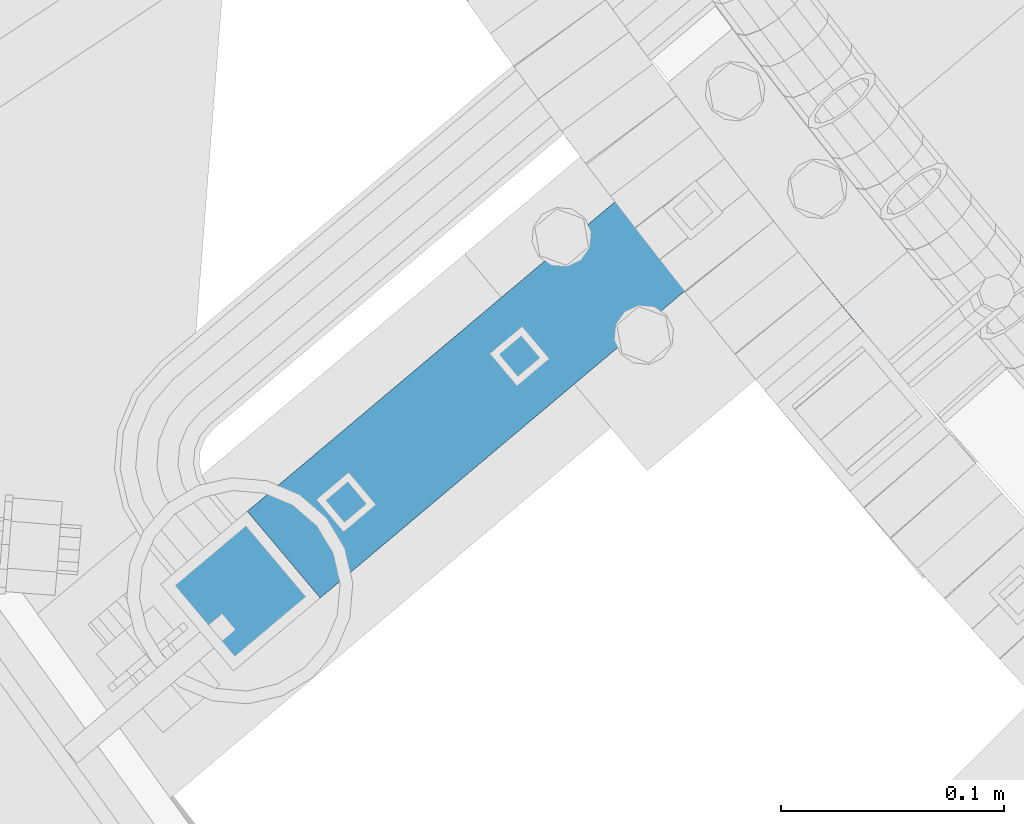
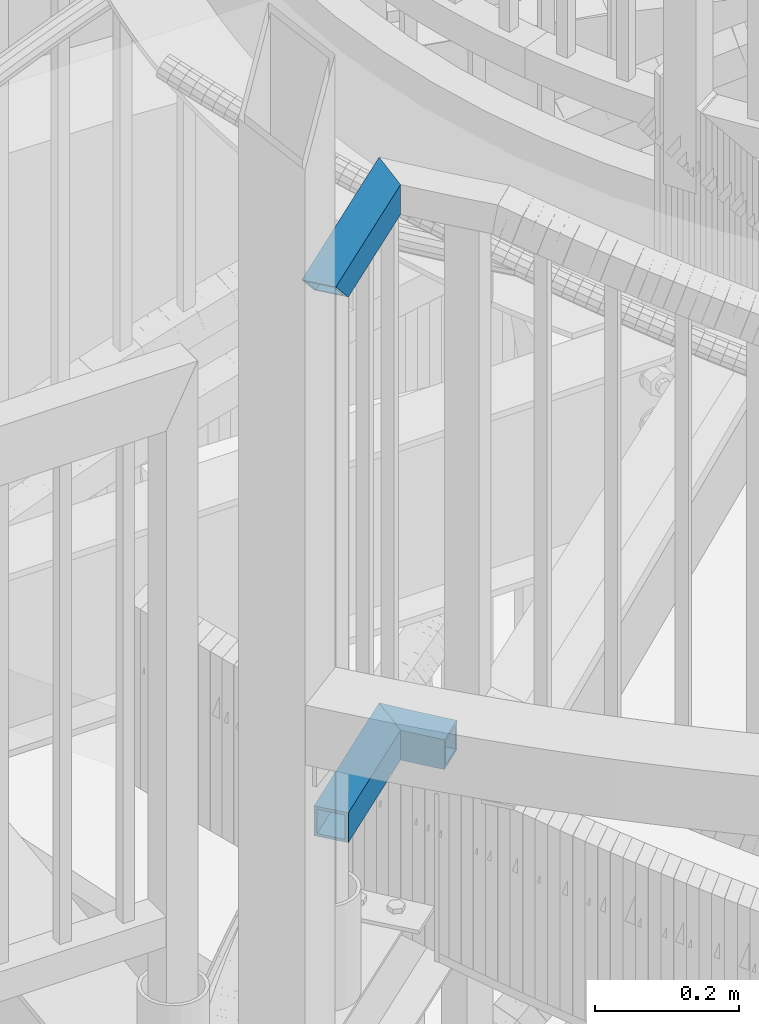
# One storey, part 463 of 975: 3 beams.
"""IFC2X3 building model written with IfcOpenShell, lengths in millimetres."""

from ifc_helpers import new_model, si_unit, frame, origin_with_axes, place, context, subcontext, project, spatial, faceted_brep, material, type_object, element, save


model = new_model("IFC2X3")

# Units and contexts
model_context = context("Model", 3, precision=1e-05, world=origin_with_axes())
body_context = subcontext(model_context, "Body", "Model", "MODEL_VIEW")
ifc_project = project(units=[si_unit("LENGTHUNIT", "METRE", prefix="MILLI"), si_unit("AREAUNIT", "SQUARE_METRE"), si_unit("VOLUMEUNIT", "CUBIC_METRE"), si_unit("MASSUNIT", "GRAM", prefix="KILO"), si_unit("TIMEUNIT", "SECOND"), si_unit("PLANEANGLEUNIT", "RADIAN"), si_unit("SOLIDANGLEUNIT", "STERADIAN"), si_unit("THERMODYNAMICTEMPERATUREUNIT", "DEGREE_CELSIUS"), si_unit("LUMINOUSINTENSITYUNIT", "LUMEN")], contexts=[model_context])

# Site, building, storey
site_placement = place(None, origin_with_axes())
site = spatial("IfcSite", under=ifc_project, at=site_placement, CompositionType="ELEMENT")
building_placement = place(site_placement, origin_with_axes())
building = spatial("IfcBuilding", under=site, at=building_placement, Name="Undefined", CompositionType="ELEMENT")
storey_placement = place(building_placement, origin_with_axes())
storey = spatial("IfcBuildingStorey", under=building, at=storey_placement, Name="Undefined", CompositionType="ELEMENT", Elevation=0.0)

# Beams
ifc_material = material()
beam_type = type_object("IfcBeamType", Name="HSS2X2X.188_TUBES", PredefinedType="NOTDEFINED")
beam_1_placement = place(storey_placement, frame((32546.1374942554, 1546.41999163262, 4203.6999526213), z_axis=(0.0, 0.0, 1.0), x_axis=(-0.631512226020782, 0.775365919025512, 0.0)))
element("IfcBeam", 1, at=beam_1_placement, inside=storey, type_object=beam_type, material=ifc_material, Name="HANDRAIL", ObjectType="HSS2X2X.188_TUBES", context=body_context, shape_type="Brep", body=[
    faceted_brep([(86.7867908267472, 25.8434800640825, -25.3999999999996), (84.8026851222021, 25.8625150428452, -25.3999999999996), (82.8185668398437, 25.8801904176144, -25.3999999999996), (82.8185668398437, 25.8801904176144, 25.3999999999996), (84.8026851222021, 25.8625150428452, 25.3999999999996), (86.7867908267472, 25.8434800640825, 25.3999999999996), (88.7708830218398, 25.8230854902686, 25.3999999999996), (88.7708830218398, 25.8230854902686, -25.3999999999996), (80.8344369113511, 25.8965061800955, -25.3999999999996), (78.8502962683924, 25.9114623226233, -25.3999999999996), (76.8661458426395, 25.9250588381765, -25.3999999999996), (76.8661458426395, 25.9250588381765, 25.3999999999996), (78.8502962683924, 25.9114623226233, 25.3999999999996), (80.8344369113511, 25.8965061800955, 25.3999999999996), (74.8819865657788, 25.9372957203668, -25.3999999999996), (72.8978193694929, 25.9481729634535, -25.3999999999996), (70.9136451854647, 25.9576905623289, -25.3999999999996), (70.9136451854647, 25.9576905623289, 25.3999999999996), (72.8978193694929, 25.9481729634535, 25.3999999999996), (74.8819865657788, 25.9372957203668, 25.3999999999996), (68.9294649453914, 25.9658485125146, -25.3999999999996), (66.9452795809702, 25.9726468101981, -25.3999999999996), (64.9610900238877, 25.9780854521705, -25.3999999999996), (64.9610900238877, 25.9780854521705, 25.3999999999996), (66.9452795809702, 25.9726468101981, 25.3999999999996), (68.9294649453914, 25.9658485125146, 25.3999999999996), (62.9768972058555, 25.982164435889, -25.3999999999996), (60.9927020585674, 25.9848837594291, -25.3999999999996), (59.0085055137242, 25.9862434215174, -25.3999999999996), (59.0085055137242, 25.9862434215174, 25.3999999999996), (60.9927020585674, 25.9848837594291, 25.3999999999996), (62.9768972058555, 25.982164435889, 25.3999999999996), (57.0243085030306, 25.9862434215174, -25.3999999999996), (55.0401119581875, 25.9848837594291, -25.3999999999996), (53.055916810903, 25.9821644358926, -25.3999999999996), (53.055916810903, 25.9821644358926, 25.3999999999996), (55.0401119581875, 25.9848837594291, 25.3999999999996), (57.0243085030306, 25.9862434215174, 25.3999999999996), (51.0717239928672, 25.9780854521778, -25.3999999999996), (49.0875344357883, 25.9726468102053, -25.3999999999996), (47.1033490713671, 25.9658485125256, -25.3999999999996), (47.1033490713671, 25.9658485125256, 25.3999999999996), (49.0875344357883, 25.9726468102053, 25.3999999999996), (51.0717239928672, 25.9780854521778, 25.3999999999996), (45.1191688312938, 25.9576905623398, -25.3999999999996), (43.1349946472656, 25.9481729634645, -25.3999999999996), (41.1508274509797, 25.9372957203777, -25.3999999999996), (41.1508274509797, 25.9372957203777, 25.3999999999996), (43.1349946472656, 25.9481729634645, 25.3999999999996), (45.1191688312938, 25.9576905623398, 25.3999999999996), (39.1666681741153, 25.9250588381874, -25.3999999999996), (37.1825177483624, 25.9114623226378, -25.3999999999996), (35.1983771054038, 25.8965061801136, -25.3999999999996), (35.1983771054038, 25.8965061801136, 25.3999999999996), (37.1825177483624, 25.9114623226378, 25.3999999999996), (39.1666681741153, 25.9250588381874, 25.3999999999996), (33.2142471769112, 25.8801904176362, -25.3999999999996), (31.2301288945564, 25.8625150428634, -25.3999999999996), (29.2460231900077, 25.8434800641007, -25.3999999999996), (29.2460231900077, 25.8434800641007, 25.3999999999996), (31.2301288945564, 25.8625150428634, 25.3999999999996), (33.2142471769112, 25.8801904176362, 25.3999999999996), (25.2778532409502, 25.8013313310003, 25.3999999999996), (27.2619309949187, 25.8230854902904, 25.3999999999996), (27.2619309949187, 25.8230854902904, -25.3999999999996), (25.2778532409502, 25.8013313310003, -25.3999999999996), (24.8836449103037, 25.7967389216101, -25.3999999999996), (24.8836449103037, 25.7967389216101, 25.3999999999996), (135.136666641316, -21.0948650812861, -20.6374999999998), (135.136666641316, -21.0948650812861, 20.6374999999998), (137.0885831946, -21.1483801701179, 20.6374999999998), (137.0885831946, -21.1483801701179, -20.6374999999998), (133.184713875333, -21.0426875470694, -20.6374999999998), (131.232725813206, -20.9918475919694, -20.6374999999998), (129.280703371518, -20.9423452398587, -20.6374999999998), (129.280703371518, -20.9423452398587, 20.6374999999998), (131.232725813206, -20.9918475919694, 20.6374999999998), (133.184713875333, -21.0426875470694, 20.6374999999998), (127.328647466864, -20.8941805139766, -20.6374999999998), (125.376559015855, -20.8473534369477, -20.6374999999998), (123.424438935112, -20.8018640307528, -20.6374999999998), (123.424438935112, -20.8018640307528, 20.6374999999998), (125.376559015855, -20.8473534369477, 20.6374999999998), (127.328647466864, -20.8941805139766, 20.6374999999998), (121.472288141274, -20.7577123167612, -20.6374999999998), (119.520107551009, -20.7148983156949, -20.6374999999998), (117.567898080972, -20.6734220476574, -20.6374999999998), (117.567898080972, -20.6734220476574, 20.6374999999998), (119.520107551009, -20.7148983156949, 20.6374999999998), (121.472288141274, -20.7577123167612, 20.6374999999998), (115.615660647847, -20.6332835321373, -20.6374999999998), (113.66339616834, -20.5944827879648, -20.6374999999998), (111.711105559141, -20.5570198333735, -20.6374999999998), (111.711105559141, -20.5570198333735, 20.6374999999998), (113.66339616834, -20.5944827879648, 20.6374999999998), (115.615660647847, -20.6332835321373, 20.6374999999998), (109.758789736985, -20.5208946859457, -20.6374999999998), (107.806449618602, -20.4861073626525, -20.6374999999998), (105.854086120737, -20.4526578798213, -20.6374999999998), (105.854086120737, -20.4526578798213, 20.6374999999998), (107.806449618602, -20.4861073626525, 20.6374999999998), (109.758789736985, -20.5208946859457, 20.6374999999998), (103.901700160135, -20.4205462531572, -20.6374999999998), (101.949292653568, -20.3897724977505, -20.6374999999998), (99.996864517816, -20.3603366280331, -20.6374999999998), (99.996864517816, -20.3603366280331, 20.6374999999998), (101.949292653568, -20.3897724977505, 20.6374999999998), (103.901700160135, -20.4205462531572, 20.6374999999998), (98.0444166696543, -20.3322386578438, -20.6374999999998), (96.0919500258824, -20.3054786003704, -20.6374999999998), (94.1394655033037, -20.2800564681747, -20.6374999999998), (94.1394655033037, -20.2800564681747, 20.6374999999998), (96.0919500258824, -20.3054786003704, 20.6374999999998), (98.0444166696543, -20.3322386578438, 20.6374999999998), (92.1869640187324, -20.2559722731967, -20.6374999999998), (90.2344464889793, -20.2332260267467, -20.6374999999998), (88.2819138308805, -20.2118177395059, -20.6374999999998), (88.2819138308805, -20.2118177395059, 20.6374999999998), (90.2344464889793, -20.2332260267467, 20.6374999999998), (92.1869640187324, -20.2559722731967, 20.6374999999998), (86.3293669612649, -20.1917474215261, -20.6374999999998), (84.3768067969722, -20.1730150822295, -20.6374999999998), (82.4242342548496, -20.1556207304129, -20.6374999999998), (82.4242342548496, -20.1556207304129, 20.6374999999998), (84.3768067969722, -20.1730150822295, 20.6374999999998), (86.3293669612649, -20.1917474215261, 20.6374999999998), (80.4716502517585, -20.1395643742435, -20.6374999999998), (78.5190557045462, -20.1248460212664, -20.6374999999998), (76.5664515300778, -20.1114656783866, -20.6374999999998), (76.5664515300778, -20.1114656783866, 20.6374999999998), (78.5190557045462, -20.1248460212664, 20.6374999999998), (80.4716502517585, -20.1395643742435, 20.6374999999998), (74.6138386452294, -20.0994233518832, -20.6374999999998), (72.6612179668664, -20.0887190474205, -20.6374999999998), (70.7085904118612, -20.0793527700225, -20.6374999999998), (70.7085904118612, -20.0793527700225, 20.6374999999998), (72.6612179668664, -20.0887190474205, 20.6374999999998), (74.6138386452294, -20.0994233518832, 20.6374999999998), (68.7559568970937, -20.0713245240804, -20.6374999999998), (66.8033183394509, -20.064634313374, -20.6374999999998), (64.8506756558163, -20.0592821410355, -20.6374999999998), (64.8506756558163, -20.0592821410355, 20.6374999999998), (66.8033183394509, -20.064634313374, 20.6374999999998), (68.7559568970937, -20.0713245240804, 20.6374999999998), (62.8980297630696, -20.0552680095825, -20.6374999999998), (60.9453815781017, -20.0525919208994, -20.6374999999998), (58.9927320177994, -20.051253876245, -20.6374999999998), (58.9927320177994, -20.051253876245, 20.6374999999998), (60.9453815781017, -20.0525919208994, 20.6374999999998), (62.8980297630696, -20.0552680095825, 20.6374999999998), (57.0400819990464, -20.051253876245, -20.6374999999998), (55.0874324387478, -20.0525919208958, -20.6374999999998), (53.1347842537798, -20.0552680095789, -20.6374999999998), (53.1347842537798, -20.0552680095789, 20.6374999999998), (55.0874324387478, -20.0525919208958, 20.6374999999998), (57.0400819990464, -20.051253876245, 20.6374999999998), (51.1821383610295, -20.0592821410282, -20.6374999999998), (49.2294956773949, -20.0646343133631, -20.6374999999998), (47.2768571197521, -20.0713245240731, -20.6374999999998), (47.2768571197521, -20.0713245240731, 20.6374999999998), (49.2294956773949, -20.0646343133631, 20.6374999999998), (51.1821383610295, -20.0592821410282, 20.6374999999998), (45.3242236049882, -20.079352770008, -20.6374999999998), (43.3715960499831, -20.0887190474095, -20.6374999999998), (41.4189753716164, -20.0994233518722, -20.6374999999998), (41.4189753716164, -20.0994233518722, 20.6374999999998), (43.3715960499831, -20.0887190474095, 20.6374999999998), (45.3242236049882, -20.079352770008, 20.6374999999998), (39.466362486768, -20.1114656783684, -20.6374999999998), (37.5137583123033, -20.1248460212519, -20.6374999999998), (35.5611637650909, -20.1395643742289, -20.6374999999998), (35.5611637650909, -20.1395643742289, 20.6374999999998), (37.5137583123033, -20.1248460212519, 20.6374999999998), (39.466362486768, -20.1114656783684, 20.6374999999998), (33.6085797619962, -20.1556207303947, -20.6374999999998), (31.6560072198772, -20.1730150822077, -20.6374999999998), (29.7034470555845, -20.1917474215043, -20.6374999999998), (29.7034470555845, -20.1917474215043, 20.6374999999998), (31.6560072198772, -20.1730150822077, 20.6374999999998), (33.6085797619962, -20.1556207303947, 20.6374999999998), (25.331699546492, 21.0391357422704, -20.6374999999998), (27.3125140146803, 21.0608541216898, -20.6374999999998), (29.2933429002369, 21.0812151518003, -20.6374999999998), (29.2933429002369, 21.0812151518003, 20.6374999999998), (27.3125140146803, 21.0608541216898, 20.6374999999998), (25.331699546492, 21.0391357422704, 20.6374999999998), (24.9799146229452, 21.0350375529088, 20.6374999999998), (24.9799146229452, 21.0350375529088, -20.6374999999998), (33.2550402029519, 21.1178651264563, 20.6374999999998), (31.274185273036, 21.1002188230304, 20.6374999999998), (31.274185273036, 21.1002188230304, -20.6374999999998), (33.2550402029519, 21.1178651264563, -20.6374999999998), (35.2359067598554, 21.1341540538015, -20.6374999999998), (35.2359067598554, 21.1341540538015, 20.6374999999998), (39.1976710340423, 21.1626597502691, 20.6374999999998), (37.216784013599, 21.149085597408, 20.6374999999998), (37.216784013599, 21.149085597408, -20.6374999999998), (39.1976710340423, 21.1626597502691, -20.6374999999998), (41.1785668910452, 21.1748765060074, -20.6374999999998), (41.1785668910452, 21.1748765060074, 20.6374999999998), (45.1403813940888, 21.1952378038186, 20.6374999999998), (43.159470654442, 21.1857358588895, 20.6374999999998), (43.159470654442, 21.1857358588895, -20.6374999999998), (45.1403813940888, 21.1952378038186, -20.6374999999998), (47.1212981798199, 21.2033823363272, -20.6374999999998), (47.1212981798199, 21.2033823363272, 20.6374999999998), (51.0831461688831, 21.2155991494328, 20.6374999999998), (49.1022200814732, 21.2101694525954, 20.6374999999998), (49.1022200814732, 21.2101694525954, -20.6374999999998), (51.0831461688831, 21.2155991494328, -20.6374999999998), (53.0640755118875, 21.2196714242891, -20.6374999999998), (53.0640755118875, 21.2196714242891, 20.6374999999998), (57.0259402440024, 21.223743701059, 20.6374999999998), (55.0450071803134, 21.222386275258, 20.6374999999998), (55.0450071803134, 21.222386275258, -20.6374999999998), (57.0259402440024, 21.223743701059, -20.6374999999998), (59.006873772767, 21.223743701059, -20.6374999999998), (59.006873772767, 21.223743701059, 20.6374999999998), (62.9687385048783, 21.2196714242855, 20.6374999999998), (60.9878068364487, 21.2223862752544, 20.6374999999998), (60.9878068364487, 21.2223862752544, -20.6374999999998), (62.9687385048783, 21.2196714242855, -20.6374999999998), (64.9496678478827, 21.2155991494292, -20.6374999999998), (64.9496678478827, 21.2155991494292, 20.6374999999998), (68.9115158369459, 21.2033823363163, 20.6374999999998), (66.9305939352926, 21.2101694525845, 20.6374999999998), (66.9305939352926, 21.2101694525845, -20.6374999999998), (68.9115158369459, 21.2033823363163, -20.6374999999998), (70.892432622677, 21.1952378038077, -20.6374999999998), (70.892432622677, 21.1952378038077, 20.6374999999998), (74.8542471257242, 21.1748765059965, 20.6374999999998), (72.8733433623238, 21.1857358588823, 20.6374999999998), (72.8733433623238, 21.1857358588823, -20.6374999999998), (74.8542471257242, 21.1748765059965, -20.6374999999998), (76.8351429827235, 21.1626597502509, -20.6374999999998), (76.8351429827235, 21.1626597502509, 20.6374999999998), (80.7969072569103, 21.1341540537869, 20.6374999999998), (78.8160300031668, 21.1490855973898, 20.6374999999998), (78.8160300031668, 21.1490855973898, -20.6374999999998), (80.7969072569103, 21.1341540537869, -20.6374999999998), (82.7777738138138, 21.1178651264418, -20.6374999999998), (82.7777738138138, 21.1178651264418, 20.6374999999998), (86.7394711165252, 21.0812151517785, 20.6374999999998), (84.7586287437298, 21.1002188230086, 20.6374999999998), (84.7586287437298, 21.1002188230086, -20.6374999999998), (86.7394711165252, 21.0812151517785, -20.6374999999998), (88.7203000020818, 21.0608541216716, -20.6374999999998), (88.7203000020818, 21.0608541216716, 20.6374999999998), (92.6819135909827, 21.0160600237032, 20.6374999999998), (90.7011144702738, 21.0391357422486, 20.6374999999998), (90.7011144702738, 21.0391357422486, -20.6374999999998), (92.6819135909827, 21.0160600237032, -20.6374999999998), (94.6626964341085, 20.9916269768764, -20.6374999999998), (94.6626964341085, 20.9916269768764, 20.6374999999998), (95.1996714824563, 20.984635346209, -20.6374999999998), (95.1996714824563, 20.984635346209, 20.6374999999998), (27.7509001859689, -20.2118177394841, 20.6374999999998), (25.7983675278665, -20.2332260267249, 20.6374999999998), (25.7983675278665, -20.2332260267249, -20.6374999999998), (27.7509001859689, -20.2118177394841, -20.6374999999998), (25.8522138334083, -24.9954216154547, -25.3999999999996), (25.8522138334083, -24.9954216154547, 25.3999999999996), (27.8014832057306, -24.9740491080775, -25.3999999999996), (29.7507667658174, -24.954012333812, -25.3999999999996), (29.7507667658174, -24.954012333812, 25.3999999999996), (27.8014832057306, -24.9740491080775, 25.3999999999996), (33.649372788037, -24.917946021571, 25.3999999999996), (31.7000635983568, -24.9353113020443, 25.3999999999996), (31.7000635983568, -24.9353113020443, -25.3999999999996), (33.649372788037, -24.917946021571, -25.3999999999996), (35.5986934195389, -24.9019165005375, -25.3999999999996), (35.5986934195389, -24.9019165005375, 25.3999999999996), (39.497365346695, -24.8738647662904, 25.3999999999996), (37.5480245775361, -24.8872227464781, 25.3999999999996), (37.5480245775361, -24.8872227464781, -25.3999999999996), (39.497365346695, -24.8738647662904, -25.3999999999996), (41.4467148116819, -24.8618425662426, -25.3999999999996), (41.4467148116819, -24.8618425662426, 25.3999999999996), (45.3454361677832, -24.8418055285292, 25.3999999999996), (43.3960720571595, -24.8511561519808, 25.3999999999996), (43.3960720571595, -24.8511561519808, -25.3999999999996), (45.3454361677832, -24.8418055285292, -25.3999999999996), (47.2948062282012, -24.8337907002715, -25.3999999999996), (47.2948062282012, -24.8337907002715, 25.3999999999996), (51.1935605370454, -24.8217684437768, 25.3999999999996), (49.2441813230762, -24.8271116709766, 25.3999999999996), (49.2441813230762, -24.8271116709766, -25.3999999999996), (51.1935605370454, -24.8217684437768, -25.3999999999996), (53.1429429547643, -24.8177610211787, -25.3999999999996), (53.1429429547643, -24.8177610211787, 25.3999999999996), (57.0417137400182, -24.8137535966998, 25.3999999999996), (55.0923276608737, -24.8150894050705, 25.3999999999996), (55.0923276608737, -24.8150894050705, -25.3999999999996), (57.0417137400182, -24.8137535966998, -25.3999999999996), (58.9911002768386, -24.8137535966998, -25.3999999999996), (58.9911002768386, -24.8137535966998, 25.3999999999996), (62.8898710620924, -24.8177610211787, 25.3999999999996), (60.940486355983, -24.8150894050741, 25.3999999999996), (60.940486355983, -24.8150894050741, -25.3999999999996), (62.8898710620924, -24.8177610211787, -25.3999999999996), (64.8392534798077, -24.8217684437805, -25.3999999999996), (64.8392534798077, -24.8217684437805, 25.3999999999996), (68.7380077886519, -24.8337907002824, 25.3999999999996), (66.7886326937805, -24.8271116709802, 25.3999999999996), (66.7886326937805, -24.8271116709802, -25.3999999999996), (68.7380077886519, -24.8337907002824, -25.3999999999996), (70.6873778490735, -24.8418055285365, -25.3999999999996), (70.6873778490735, -24.8418055285365, 25.3999999999996), (74.5860992051748, -24.8618425662535, 25.3999999999996), (72.6367419596936, -24.8511561519954, 25.3999999999996), (72.6367419596936, -24.8511561519954, -25.3999999999996), (74.5860992051748, -24.8618425662535, -25.3999999999996), (76.5354486701617, -24.8738647663049, -25.3999999999996), (76.5354486701617, -24.8738647663049, 25.3999999999996), (80.4341205973142, -24.9019165005593, 25.3999999999996), (78.484789439317, -24.8872227464963, 25.3999999999996), (78.484789439317, -24.8872227464963, -25.3999999999996), (80.4341205973142, -24.9019165005593, -25.3999999999996), (82.3834412288161, -24.9179460215892, -25.3999999999996), (82.3834412288161, -24.9179460215892, 25.3999999999996), (86.2820472510393, -24.9540123338302, 25.3999999999996), (84.3327504184999, -24.9353113020661, 25.3999999999996), (84.3327504184999, -24.9353113020661, -25.3999999999996), (86.2820472510393, -24.9540123338302, -25.3999999999996), (88.2313308111261, -24.9740491081029, -25.3999999999996), (88.2313308111261, -24.9740491081029, 25.3999999999996), (92.1298544527017, -25.0181298459174, 25.3999999999996), (90.1806001834484, -24.9954216154765, 25.3999999999996), (90.1806001834484, -24.9954216154765, -25.3999999999996), (92.1298544527017, -25.0181298459174, -25.3999999999996), (94.079092703596, -25.0421737887555, -25.3999999999996), (94.079092703596, -25.0421737887555, 25.3999999999996), (97.9775174891656, -25.0942687658535, 25.3999999999996), (96.0283140208448, -25.0675534327092, 25.3999999999996), (96.0283140208448, -25.0675534327092, -25.3999999999996), (97.9775174891656, -25.0942687658535, -25.3999999999996), (99.9267021932901, -25.1223197756481, -25.3999999999996), (99.9267021932901, -25.1223197756481, 25.3999999999996), (103.82501164791, -25.18242877187, 25.3999999999996), (101.875867217954, -25.1517064489199, 25.3999999999996), (101.875867217954, -25.1517064489199, -25.3999999999996), (103.82501164791, -25.18242877187, -25.3999999999996), (105.774134567906, -25.2144867300776, -25.3999999999996), (105.774134567906, -25.2144867300776, 25.3999999999996), (109.67231221711, -25.2826094914053, 25.3999999999996), (107.723235062716, -25.2478803084778, 25.3999999999996), (107.723235062716, -25.2478803084778, -25.3999999999996), (109.67231221711, -25.2826094914053, -25.3999999999996), (111.621365115883, -25.3186742625403, -25.3999999999996), (111.621365115883, -25.3186742625403, 25.3999999999996), (115.519394485782, -25.3948105010786, 25.3999999999996), (113.570392843842, -25.3560746049516, 25.3999999999996), (113.570392843842, -25.3560746049516, -25.3999999999996), (115.519394485782, -25.3948105010786, -25.3999999999996), (117.468369126538, -25.4348819327315, -25.3999999999996), (117.468369126538, -25.4348819327315, 25.3999999999996), (121.366233743844, -25.519031326734, 25.3999999999996), (119.41731585094, -25.4762888811019, 25.3999999999996), (119.41731585094, -25.4762888811019, -25.3999999999996), (121.366233743844, -25.519031326734, -25.3999999999996), (123.315121890111, -25.5631092495605, -25.3999999999996), (123.315121890111, -25.5631092495605, 25.3999999999996), (127.212805282259, -25.6552714434001, 25.3999999999996), (125.26397937462, -25.6085226288924, 25.3999999999996), (125.26397937462, -25.6085226288924, -25.3999999999996), (127.212805282259, -25.6552714434001, -25.3999999999996), (129.161598697938, -25.7033556711285, -25.3999999999996), (129.161598697938, -25.7033556711285, 25.3999999999996), (133.05908439311, -25.803530275316, 25.3999999999996), (131.110358706574, -25.7527752895039, 25.3999999999996), (131.110358706574, -25.7527752895039, -25.3999999999996), (133.05908439311, -25.803530275316, -25.3999999999996), (135.007774842492, -25.8556206047397, -25.3999999999996), (135.007774842492, -25.8556206047397, 25.3999999999996), (138.905046369709, -25.9638071959453, 25.3999999999996), (136.9564291397, -25.9090462533168, 25.3999999999996), (136.9564291397, -25.9090462533168, -25.3999999999996), (138.905046369709, -25.9638071959453, -25.3999999999996), (140.853625617536, -26.0199034069265, -25.3999999999996), (140.853625617536, -26.0199034069265, 25.3999999999996), (142.23178671948, -26.0605234508002, 25.3999999999996), (90.3802031145278, 25.8054403120077, 25.3999999999996), (90.3802031145278, 25.8054403120077, -25.3999999999996), (142.23178671948, -26.0605234508002, -25.3999999999996)], [[[0, 1, 2, 3, 4, 5, 6, 7]], [[8, 9, 10, 11, 12, 13, 3, 2]], [[14, 15, 16, 17, 18, 19, 11, 10]], [[20, 21, 22, 23, 24, 25, 17, 16]], [[26, 27, 28, 29, 30, 31, 23, 22]], [[32, 33, 34, 35, 36, 37, 29, 28]], [[38, 39, 40, 41, 42, 43, 35, 34]], [[44, 45, 46, 47, 48, 49, 41, 40]], [[50, 51, 52, 53, 54, 55, 47, 46]], [[56, 57, 58, 59, 60, 61, 53, 52]], [[62, 63, 59, 58, 64, 65, 66, 67]], [[68, 69, 70, 71]], [[72, 73, 74, 75, 76, 77, 69, 68]], [[78, 79, 80, 81, 82, 83, 75, 74]], [[84, 85, 86, 87, 88, 89, 81, 80]], [[90, 91, 92, 93, 94, 95, 87, 86]], [[96, 97, 98, 99, 100, 101, 93, 92]], [[102, 103, 104, 105, 106, 107, 99, 98]], [[108, 109, 110, 111, 112, 113, 105, 104]], [[114, 115, 116, 117, 118, 119, 111, 110]], [[120, 121, 122, 123, 124, 125, 117, 116]], [[126, 127, 128, 129, 130, 131, 123, 122]], [[132, 133, 134, 135, 136, 137, 129, 128]], [[138, 139, 140, 141, 142, 143, 135, 134]], [[144, 145, 146, 147, 148, 149, 141, 140]], [[150, 151, 152, 153, 154, 155, 147, 146]], [[156, 157, 158, 159, 160, 161, 153, 152]], [[162, 163, 164, 165, 166, 167, 159, 158]], [[168, 169, 170, 171, 172, 173, 165, 164]], [[174, 175, 176, 177, 178, 179, 171, 170]], [[180, 181, 182, 183, 184, 185, 186, 187]], [[188, 189, 183, 182, 190, 191, 192, 193]], [[194, 195, 193, 192, 196, 197, 198, 199]], [[200, 201, 199, 198, 202, 203, 204, 205]], [[206, 207, 205, 204, 208, 209, 210, 211]], [[212, 213, 211, 210, 214, 215, 216, 217]], [[218, 219, 217, 216, 220, 221, 222, 223]], [[224, 225, 223, 222, 226, 227, 228, 229]], [[230, 231, 229, 228, 232, 233, 234, 235]], [[236, 237, 235, 234, 238, 239, 240, 241]], [[242, 243, 241, 240, 244, 245, 246, 247]], [[248, 249, 247, 246, 250, 251, 252, 253]], [[253, 252, 254, 255]], [[69, 77, 76, 75, 83, 82, 81, 89, 88, 87, 95, 94, 93, 101, 100, 99, 107, 106, 105, 113, 112, 111, 119, 118, 117, 125, 124, 123, 131, 130, 129, 137, 136, 135, 143, 142, 141, 149, 148, 147, 155, 154, 153, 161, 160, 159, 167, 166, 165, 173, 172, 171, 179, 178, 177, 256, 257, 186, 185, 184, 183, 189, 188, 193, 195, 194, 199, 201, 200, 205, 207, 206, 211, 213, 212, 217, 219, 218, 223, 225, 224, 229, 231, 230, 235, 237, 236, 241, 243, 242, 247, 249, 248, 253, 255, 70]], [[252, 251, 250, 246, 245, 244, 240, 239, 238, 234, 233, 232, 228, 227, 226, 222, 221, 220, 216, 215, 214, 210, 209, 208, 204, 203, 202, 198, 197, 196, 192, 191, 190, 182, 181, 180, 187, 258, 259, 176, 175, 174, 170, 169, 168, 164, 163, 162, 158, 157, 156, 152, 151, 150, 146, 145, 144, 140, 139, 138, 134, 133, 132, 128, 127, 126, 122, 121, 120, 116, 115, 114, 110, 109, 108, 104, 103, 102, 98, 97, 96, 92, 91, 90, 86, 85, 84, 80, 79, 78, 74, 73, 72, 68, 71, 254]], [[256, 177, 176, 259, 258, 257]], [[66, 260, 261, 67], [187, 186, 257, 258]], [[262, 263, 264, 265, 261, 260]], [[266, 267, 264, 263, 268, 269, 270, 271]], [[272, 273, 271, 270, 274, 275, 276, 277]], [[278, 279, 277, 276, 280, 281, 282, 283]], [[284, 285, 283, 282, 286, 287, 288, 289]], [[290, 291, 289, 288, 292, 293, 294, 295]], [[296, 297, 295, 294, 298, 299, 300, 301]], [[302, 303, 301, 300, 304, 305, 306, 307]], [[308, 309, 307, 306, 310, 311, 312, 313]], [[314, 315, 313, 312, 316, 317, 318, 319]], [[320, 321, 319, 318, 322, 323, 324, 325]], [[326, 327, 325, 324, 328, 329, 330, 331]], [[332, 333, 331, 330, 334, 335, 336, 337]], [[338, 339, 337, 336, 340, 341, 342, 343]], [[344, 345, 343, 342, 346, 347, 348, 349]], [[350, 351, 349, 348, 352, 353, 354, 355]], [[356, 357, 355, 354, 358, 359, 360, 361]], [[362, 363, 361, 360, 364, 365, 366, 367]], [[368, 369, 367, 366, 370, 371, 372, 373]], [[374, 375, 373, 372, 376, 377, 378, 379]], [[6, 5, 4, 3, 13, 12, 11, 19, 18, 17, 25, 24, 23, 31, 30, 29, 37, 36, 35, 43, 42, 41, 49, 48, 47, 55, 54, 53, 61, 60, 59, 63, 62, 67, 261, 265, 264, 267, 266, 271, 273, 272, 277, 279, 278, 283, 285, 284, 289, 291, 290, 295, 297, 296, 301, 303, 302, 307, 309, 308, 313, 315, 314, 319, 321, 320, 325, 327, 326, 331, 333, 332, 337, 339, 338, 343, 345, 344, 349, 351, 350, 355, 357, 356, 361, 363, 362, 367, 369, 368, 373, 375, 374, 379, 380, 381]], [[7, 6, 381, 382]], [[378, 377, 376, 372, 371, 370, 366, 365, 364, 360, 359, 358, 354, 353, 352, 348, 347, 346, 342, 341, 340, 336, 335, 334, 330, 329, 328, 324, 323, 322, 318, 317, 316, 312, 311, 310, 306, 305, 304, 300, 299, 298, 294, 293, 292, 288, 287, 286, 282, 281, 280, 276, 275, 274, 270, 269, 268, 263, 262, 260, 66, 65, 64, 58, 57, 56, 52, 51, 50, 46, 45, 44, 40, 39, 38, 34, 33, 32, 28, 27, 26, 22, 21, 20, 16, 15, 14, 10, 9, 8, 2, 1, 0, 7, 382, 383]], [[379, 378, 383, 380]], [[382, 381, 380, 383], [254, 71, 70, 255]]]),
])
beam_2_placement = place(storey_placement, frame((32269.9182476634, 1465.76976512464, 5130.8), z_axis=(0.0, 0.0, 1.0), x_axis=(0.76502246600244, 0.644003592002052, 0.0)))
element("IfcBeam", 2, at=beam_2_placement, inside=storey, type_object=beam_type, material=ifc_material, Name="HANDRAIL", ObjectType="HSS2X2X.188_TUBES", context=body_context, shape_type="Brep", body=[
    faceted_brep([(20.6375002484237, 20.6374999999971, -20.6374999999998), (20.6375002484456, -20.637500000008, -20.6374999999998), (243.837695077644, -20.6375000000698, -20.6374999999998), (286.485522619387, 20.6374999999243, -20.6374999999998), (-20.6375002658569, -20.6374999999971, 20.6374999999998), (243.837695077644, -20.6375000000698, 20.6374999999998), (-20.6375002658751, 20.637500000008, 20.6374999999998), (286.485522619387, 20.6374999999243, 20.6374999999998), (25.4000003077635, 25.3999999999942, -25.3999999999996), (-25.4000003252186, 25.4000000000087, 25.3999999999996), (291.406425797279, 25.3999999999214, 25.3999999999996), (291.406425797279, 25.3999999999214, -25.3999999999996), (-25.4000003251967, -25.3999999999942, 25.3999999999996), (238.916791899748, -25.4000000000706, 25.3999999999996), (25.4000003077854, -25.4000000000087, -25.3999999999996), (238.916791899748, -25.4000000000706, -25.3999999999996)], [[[0, 1, 2, 3]], [[1, 4, 5, 2]], [[4, 6, 7, 5]], [[6, 0, 3, 7]], [[8, 9, 10, 11]], [[9, 12, 13, 10]], [[12, 14, 15, 13]], [[14, 8, 11, 15]], [[13, 15, 11, 10], [5, 7, 3, 2]], [[14, 12, 9, 8], [6, 4, 1, 0]]]),
])
beam_3_placement = place(storey_placement, frame((32269.9182476634, 1465.76976512469, 4203.69995262131), z_axis=(0.0, 0.0, 1.0), x_axis=(0.76502246600244, 0.644003592002052, 0.0)))
element("IfcBeam", 3, at=beam_3_placement, inside=storey, type_object=beam_type, material=ifc_material, Name="HANDRAIL", ObjectType="HSS2X2X.188_TUBES", context=body_context, shape_type="Brep", body=[
    faceted_brep([(25.3999997357314, 20.6374999999898, -20.6374999999998), (25.4000002641624, -20.6375000000153, -20.6374999999998), (243.837695077644, -20.6375000000698, -20.6374999999998), (286.485522619387, 20.6374999999243, -20.6374999999998), (25.4000002641624, -20.6375000000153, 20.6374999999998), (243.837695077644, -20.6375000000698, 20.6374999999998), (25.3999997357314, 20.6374999999898, 20.6374999999998), (286.485522619387, 20.6374999999243, 20.6374999999998), (25.4000003077635, 25.3999999999942, -25.3999999999996), (25.3999996747552, 25.3999999999905, 25.3999999999996), (291.406425797279, 25.3999999999214, 25.3999999999996), (291.406425797279, 25.3999999999214, -25.3999999999996), (25.4000003251349, -25.4000000000124, 25.3999999999996), (238.916791899748, -25.4000000000706, 25.3999999999996), (25.4000003077854, -25.4000000000087, -25.3999999999996), (238.916791899748, -25.4000000000706, -25.3999999999996)], [[[0, 1, 2, 3]], [[1, 4, 5, 2]], [[4, 6, 7, 5]], [[6, 0, 3, 7]], [[8, 9, 10, 11]], [[9, 12, 13, 10]], [[12, 14, 15, 13]], [[14, 8, 11, 15]], [[13, 15, 11, 10], [5, 7, 3, 2]], [[14, 12, 9, 8], [6, 4, 1, 0]]]),
])

save(model, "model.ifc")
